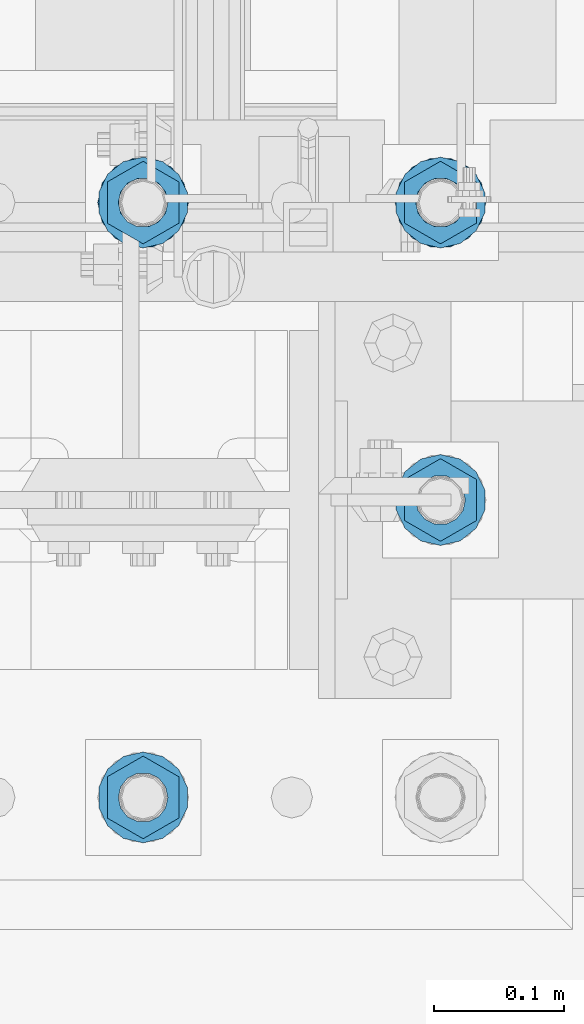
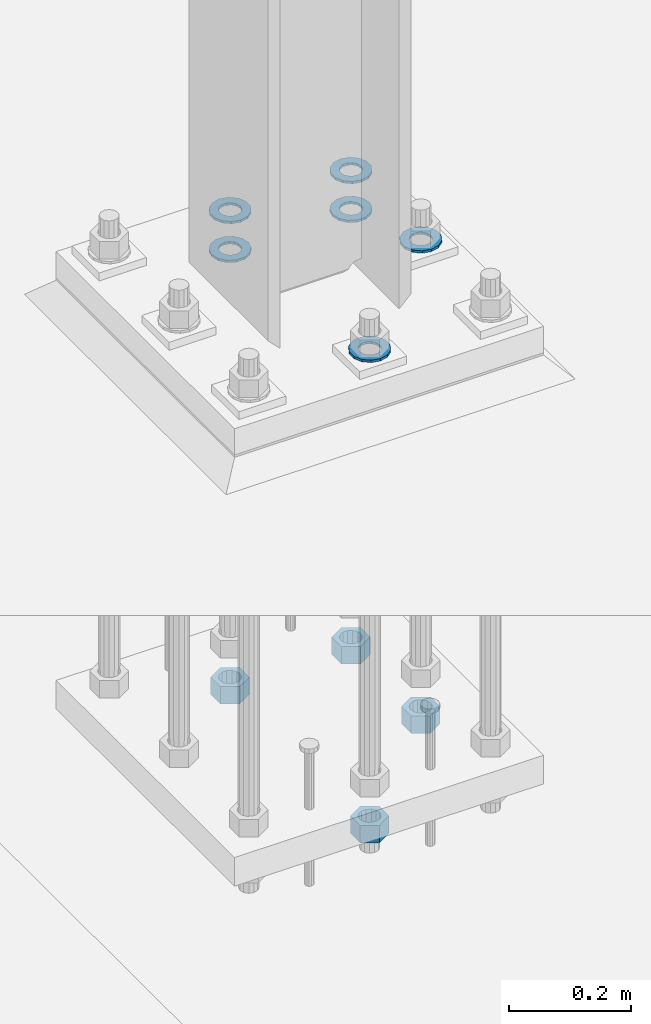
# One storey, part 889 of 1876: 10 columns, 1 element without a shape of its own.
"""IFC2X3 building model written with IfcOpenShell, lengths in millimetres."""

from ifc_helpers import new_model, si_unit, frame, origin_with_axes, place, context, subcontext, project, spatial, faceted_brep, material, type_object, element, aggregate, save


model = new_model("IFC2X3")

# Units and contexts
model_context = context("Model", 3, precision=1e-05, world=origin_with_axes())
body_context = subcontext(model_context, "Body", "Model", "MODEL_VIEW")
ifc_project = project(units=[si_unit("LENGTHUNIT", "METRE", prefix="MILLI"), si_unit("AREAUNIT", "SQUARE_METRE"), si_unit("VOLUMEUNIT", "CUBIC_METRE"), si_unit("MASSUNIT", "GRAM", prefix="KILO"), si_unit("TIMEUNIT", "SECOND"), si_unit("PLANEANGLEUNIT", "RADIAN"), si_unit("SOLIDANGLEUNIT", "STERADIAN"), si_unit("THERMODYNAMICTEMPERATUREUNIT", "DEGREE_CELSIUS"), si_unit("LUMINOUSINTENSITYUNIT", "LUMEN")], contexts=[model_context])

# Site, building, storey
site_placement = place(None, origin_with_axes())
site = spatial("IfcSite", under=ifc_project, at=site_placement, CompositionType="ELEMENT")
building_placement = place(site_placement, origin_with_axes())
building = spatial("IfcBuilding", under=site, at=building_placement, Name="Undefined", CompositionType="ELEMENT")
storey_placement = place(building_placement, origin_with_axes())
storey = spatial("IfcBuildingStorey", under=building, at=storey_placement, Name="Undefined", CompositionType="ELEMENT", Elevation=0.0)

# Assembly, columns
assembly_placement = place(storey_placement, origin_with_axes())
assembly = element("IfcElementAssembly", 1, at=assembly_placement, inside=storey, Name="TEMPLATE", AssemblyPlace="NOTDEFINED", PredefinedType="RIGID_FRAME")
ifc_material_1 = material(Name="STEEL/F436")
column_type_1 = type_object("IfcColumnType", Name="1-3/8_WASHER", PredefinedType="NOTDEFINED")
column_1_placement = place(assembly_placement, frame((1955.8, -6883.4, 38.1), z_axis=(0.0, -1.0, 0.0), x_axis=(0.0, 0.0, -1.0)))
column_1 = element("IfcColumn", 2, at=column_1_placement, type_object=column_type_1, material=ifc_material_1, Name="WASHER", ObjectType="1-3/8_WASHER", context=body_context, shape_type="Brep", body=[
    faceted_brep([(0.0, -34.9199981689453, 0.0), (0.0, -31.4618312174289, -15.1512193755207), (4.7625, -31.4618312174289, -15.1512193755207), (4.7625, -34.9199981689453, 0.0), (0.0, -21.7722627392632, -27.3015539362077), (4.7625, -21.7722627392632, -27.3015539362077), (0.0, -7.77043060630604, -34.0444809082428), (4.7625, -7.77043060630604, -34.0444809082428), (0.0, 7.77043060630695, -34.0444809082428), (4.7625, 7.77043060630695, -34.0444809082428), (0.0, 21.7722627392632, -27.3015539362077), (4.7625, 21.7722627392632, -27.3015539362077), (0.0, 31.4618312174298, -15.1512193755207), (4.7625, 31.4618312174298, -15.1512193755207), (0.0, 34.9199981689453, 0.0), (4.7625, 34.9199981689453, 0.0), (0.0, 31.4618312174289, 15.1512193755207), (4.7625, 31.4618312174289, 15.1512193755207), (0.0, 21.7722627392632, 27.3015539362077), (4.7625, 21.7722627392632, 27.3015539362077), (0.0, 7.77043060630604, 34.0444809082428), (4.7625, 7.77043060630604, 34.0444809082428), (0.0, -7.77043060630695, 34.0444809082428), (4.7625, -7.77043060630695, 34.0444809082428), (0.0, -21.7722627392632, 27.3015539362077), (4.7625, -21.7722627392632, 27.3015539362077), (0.0, -31.4618312174298, 15.1512193755207), (4.7625, -31.4618312174298, 15.1512193755207), (0.0, 0.0, 19.0499999999993), (0.0, 8.2654848991624, 17.1634562461559), (4.7625, 8.2654848991624, 17.1634562461559), (4.7625, 0.0, 19.0499992370605), (0.0, 14.8938891445259, 11.8774802497237), (4.7625, 14.8938891445259, 11.8774802497237), (0.0, 18.5723759832526, 4.2390236220981), (4.7625, 18.5723759832526, 4.2390236220981), (0.0, 18.5723759832526, -4.2390236220981), (4.7625, 18.5723759832526, -4.2390236220981), (0.0, 14.8938891445259, -11.8774802497237), (4.7625, 14.8938891445259, -11.8774802497237), (0.0, 8.2654848991624, -17.1634562461568), (4.7625, 8.2654848991624, -17.1634562461568), (0.0, 0.0, -19.05), (4.7625, 0.0, -19.0499992370605), (0.0, -8.2654848991624, -17.1634562461559), (4.7625, -8.2654848991624, -17.1634562461559), (0.0, -14.8938891445259, -11.8774802497237), (4.7625, -14.8938891445259, -11.8774802497237), (0.0, -18.5723759832526, -4.2390236220981), (4.7625, -18.5723759832526, -4.2390236220981), (0.0, -18.5723759832526, 4.2390236220981), (4.7625, -18.5723759832526, 4.2390236220981), (0.0, -14.8938891445259, 11.8774802497237), (4.7625, -14.8938891445259, 11.8774802497237), (0.0, -8.2654848991624, 17.1634562461568), (4.7625, -8.2654848991624, 17.1634562461568)], [[[0, 1, 2, 3]], [[1, 4, 5, 2]], [[4, 6, 7, 5]], [[6, 8, 9, 7]], [[8, 10, 11, 9]], [[10, 12, 13, 11]], [[12, 14, 15, 13]], [[14, 16, 17, 15]], [[16, 18, 19, 17]], [[18, 20, 21, 19]], [[20, 22, 23, 21]], [[22, 24, 25, 23]], [[24, 26, 27, 25]], [[26, 0, 3, 27]], [[28, 29, 30, 31]], [[29, 32, 33, 30]], [[32, 34, 35, 33]], [[34, 36, 37, 35]], [[36, 38, 39, 37]], [[38, 40, 41, 39]], [[40, 42, 43, 41]], [[42, 44, 45, 43]], [[44, 46, 47, 45]], [[46, 48, 49, 47]], [[48, 50, 51, 49]], [[50, 52, 53, 51]], [[52, 54, 55, 53]], [[54, 28, 31, 55]], [[5, 7, 9, 11, 13, 15, 17, 19, 21, 23, 25, 27, 3, 2], [33, 35, 37, 39, 41, 43, 45, 47, 49, 51, 53, 55, 31, 30]], [[26, 24, 22, 20, 18, 16, 14, 12, 10, 8, 6, 4, 1, 0], [54, 52, 50, 48, 46, 44, 42, 40, 38, 36, 34, 32, 29, 28]]]),
])
column_2_placement = place(assembly_placement, frame((1727.2, -6883.4, 38.1), z_axis=(0.0, -1.0, 0.0), x_axis=(0.0, 0.0, -1.0)))
column_2 = element("IfcColumn", 3, at=column_2_placement, type_object=column_type_1, material=ifc_material_1, Name="WASHER", ObjectType="1-3/8_WASHER", context=body_context, shape_type="Brep", body=[
    faceted_brep([(0.0, -34.9199981689453, 0.0), (0.0, -31.4618312174289, -15.1512193755207), (4.7625, -31.4618312174289, -15.1512193755207), (4.7625, -34.9199981689453, 0.0), (0.0, -21.7722627392632, -27.3015539362077), (4.7625, -21.7722627392632, -27.3015539362077), (0.0, -7.77043060630604, -34.0444809082428), (4.7625, -7.77043060630604, -34.0444809082428), (0.0, 7.77043060630695, -34.0444809082428), (4.7625, 7.77043060630695, -34.0444809082428), (0.0, 21.7722627392632, -27.3015539362077), (4.7625, 21.7722627392632, -27.3015539362077), (0.0, 31.4618312174298, -15.1512193755207), (4.7625, 31.4618312174298, -15.1512193755207), (0.0, 34.9199981689453, 0.0), (4.7625, 34.9199981689453, 0.0), (0.0, 31.4618312174289, 15.1512193755207), (4.7625, 31.4618312174289, 15.1512193755207), (0.0, 21.7722627392632, 27.3015539362077), (4.7625, 21.7722627392632, 27.3015539362077), (0.0, 7.77043060630604, 34.0444809082428), (4.7625, 7.77043060630604, 34.0444809082428), (0.0, -7.77043060630695, 34.0444809082428), (4.7625, -7.77043060630695, 34.0444809082428), (0.0, -21.7722627392632, 27.3015539362077), (4.7625, -21.7722627392632, 27.3015539362077), (0.0, -31.4618312174298, 15.1512193755207), (4.7625, -31.4618312174298, 15.1512193755207), (0.0, 0.0, 19.0499999999993), (0.0, 8.2654848991624, 17.1634562461559), (4.7625, 8.2654848991624, 17.1634562461559), (4.7625, 0.0, 19.0499992370605), (0.0, 14.8938891445259, 11.8774802497237), (4.7625, 14.8938891445259, 11.8774802497237), (0.0, 18.5723759832526, 4.2390236220981), (4.7625, 18.5723759832526, 4.2390236220981), (0.0, 18.5723759832526, -4.2390236220981), (4.7625, 18.5723759832526, -4.2390236220981), (0.0, 14.8938891445259, -11.8774802497237), (4.7625, 14.8938891445259, -11.8774802497237), (0.0, 8.2654848991624, -17.1634562461568), (4.7625, 8.2654848991624, -17.1634562461568), (0.0, 0.0, -19.05), (4.7625, 0.0, -19.0499992370605), (0.0, -8.2654848991624, -17.1634562461559), (4.7625, -8.2654848991624, -17.1634562461559), (0.0, -14.8938891445259, -11.8774802497237), (4.7625, -14.8938891445259, -11.8774802497237), (0.0, -18.5723759832526, -4.2390236220981), (4.7625, -18.5723759832526, -4.2390236220981), (0.0, -18.5723759832526, 4.2390236220981), (4.7625, -18.5723759832526, 4.2390236220981), (0.0, -14.8938891445259, 11.8774802497237), (4.7625, -14.8938891445259, 11.8774802497237), (0.0, -8.2654848991624, 17.1634562461568), (4.7625, -8.2654848991624, 17.1634562461568)], [[[0, 1, 2, 3]], [[1, 4, 5, 2]], [[4, 6, 7, 5]], [[6, 8, 9, 7]], [[8, 10, 11, 9]], [[10, 12, 13, 11]], [[12, 14, 15, 13]], [[14, 16, 17, 15]], [[16, 18, 19, 17]], [[18, 20, 21, 19]], [[20, 22, 23, 21]], [[22, 24, 25, 23]], [[24, 26, 27, 25]], [[26, 0, 3, 27]], [[28, 29, 30, 31]], [[29, 32, 33, 30]], [[32, 34, 35, 33]], [[34, 36, 37, 35]], [[36, 38, 39, 37]], [[38, 40, 41, 39]], [[40, 42, 43, 41]], [[42, 44, 45, 43]], [[44, 46, 47, 45]], [[46, 48, 49, 47]], [[48, 50, 51, 49]], [[50, 52, 53, 51]], [[52, 54, 55, 53]], [[54, 28, 31, 55]], [[5, 7, 9, 11, 13, 15, 17, 19, 21, 23, 25, 27, 3, 2], [33, 35, 37, 39, 41, 43, 45, 47, 49, 51, 53, 55, 31, 30]], [[26, 24, 22, 20, 18, 16, 14, 12, 10, 8, 6, 4, 1, 0], [54, 52, 50, 48, 46, 44, 42, 40, 38, 36, 34, 32, 29, 28]]]),
])
column_3_placement = place(assembly_placement, frame((1955.8, -7112.0, 115.8875), z_axis=(1.0, 0.0, 0.0), x_axis=(0.0, 0.0, -1.0)))
column_3 = element("IfcColumn", 4, at=column_3_placement, type_object=column_type_1, material=ifc_material_1, Name="WASHER", ObjectType="1-3/8_WASHER", context=body_context, shape_type="Brep", body=[
    faceted_brep([(0.0, -34.9199981689453, 0.0), (0.0, -31.4618312174289, -15.1512193755207), (4.7625, -31.4618312174289, -15.1512193755207), (4.7625, -34.9199981689453, 0.0), (0.0, -21.7722627392632, -27.3015539362077), (4.7625, -21.7722627392632, -27.3015539362077), (0.0, -7.77043060630604, -34.0444809082428), (4.7625, -7.77043060630604, -34.0444809082428), (0.0, 7.77043060630695, -34.0444809082428), (4.7625, 7.77043060630695, -34.0444809082428), (0.0, 21.7722627392632, -27.3015539362077), (4.7625, 21.7722627392632, -27.3015539362077), (0.0, 31.4618312174298, -15.1512193755207), (4.7625, 31.4618312174298, -15.1512193755207), (0.0, 34.9199981689453, 0.0), (4.7625, 34.9199981689453, 0.0), (0.0, 31.4618312174289, 15.1512193755207), (4.7625, 31.4618312174289, 15.1512193755207), (0.0, 21.7722627392632, 27.3015539362077), (4.7625, 21.7722627392632, 27.3015539362077), (0.0, 7.77043060630604, 34.0444809082428), (4.7625, 7.77043060630604, 34.0444809082428), (0.0, -7.77043060630695, 34.0444809082428), (4.7625, -7.77043060630695, 34.0444809082428), (0.0, -21.7722627392632, 27.3015539362077), (4.7625, -21.7722627392632, 27.3015539362077), (0.0, -31.4618312174298, 15.1512193755207), (4.7625, -31.4618312174298, 15.1512193755207), (0.0, 0.0, 19.0499999999993), (0.0, 8.2654848991624, 17.1634562461559), (4.7625, 8.2654848991624, 17.1634562461559), (4.7625, 0.0, 19.0499992370605), (0.0, 14.8938891445259, 11.8774802497237), (4.7625, 14.8938891445259, 11.8774802497237), (0.0, 18.5723759832526, 4.2390236220981), (4.7625, 18.5723759832526, 4.2390236220981), (0.0, 18.5723759832526, -4.2390236220981), (4.7625, 18.5723759832526, -4.2390236220981), (0.0, 14.8938891445259, -11.8774802497237), (4.7625, 14.8938891445259, -11.8774802497237), (0.0, 8.2654848991624, -17.1634562461568), (4.7625, 8.2654848991624, -17.1634562461568), (0.0, 0.0, -19.05), (4.7625, 0.0, -19.0499992370605), (0.0, -8.2654848991624, -17.1634562461559), (4.7625, -8.2654848991624, -17.1634562461559), (0.0, -14.8938891445259, -11.8774802497237), (4.7625, -14.8938891445259, -11.8774802497237), (0.0, -18.5723759832526, -4.2390236220981), (4.7625, -18.5723759832526, -4.2390236220981), (0.0, -18.5723759832526, 4.2390236220981), (4.7625, -18.5723759832526, 4.2390236220981), (0.0, -14.8938891445259, 11.8774802497237), (4.7625, -14.8938891445259, 11.8774802497237), (0.0, -8.2654848991624, 17.1634562461568), (4.7625, -8.2654848991624, 17.1634562461568)], [[[0, 1, 2, 3]], [[1, 4, 5, 2]], [[4, 6, 7, 5]], [[6, 8, 9, 7]], [[8, 10, 11, 9]], [[10, 12, 13, 11]], [[12, 14, 15, 13]], [[14, 16, 17, 15]], [[16, 18, 19, 17]], [[18, 20, 21, 19]], [[20, 22, 23, 21]], [[22, 24, 25, 23]], [[24, 26, 27, 25]], [[26, 0, 3, 27]], [[28, 29, 30, 31]], [[29, 32, 33, 30]], [[32, 34, 35, 33]], [[34, 36, 37, 35]], [[36, 38, 39, 37]], [[38, 40, 41, 39]], [[40, 42, 43, 41]], [[42, 44, 45, 43]], [[44, 46, 47, 45]], [[46, 48, 49, 47]], [[48, 50, 51, 49]], [[50, 52, 53, 51]], [[52, 54, 55, 53]], [[54, 28, 31, 55]], [[5, 7, 9, 11, 13, 15, 17, 19, 21, 23, 25, 27, 3, 2], [33, 35, 37, 39, 41, 43, 45, 47, 49, 51, 53, 55, 31, 30]], [[26, 24, 22, 20, 18, 16, 14, 12, 10, 8, 6, 4, 1, 0], [54, 52, 50, 48, 46, 44, 42, 40, 38, 36, 34, 32, 29, 28]]]),
])
column_4_placement = place(assembly_placement, frame((1955.8, -6883.4, 115.8875), z_axis=(-1.0, 0.0, 0.0), x_axis=(0.0, 0.0, -1.0)))
column_4 = element("IfcColumn", 5, at=column_4_placement, type_object=column_type_1, material=ifc_material_1, Name="WASHER", ObjectType="1-3/8_WASHER", context=body_context, shape_type="Brep", body=[
    faceted_brep([(0.0, -34.9199981689453, 0.0), (0.0, -31.4618312174289, -15.1512193755207), (4.7625, -31.4618312174289, -15.1512193755207), (4.7625, -34.9199981689453, 0.0), (0.0, -21.7722627392632, -27.3015539362077), (4.7625, -21.7722627392632, -27.3015539362077), (0.0, -7.77043060630604, -34.0444809082428), (4.7625, -7.77043060630604, -34.0444809082428), (0.0, 7.77043060630695, -34.0444809082428), (4.7625, 7.77043060630695, -34.0444809082428), (0.0, 21.7722627392632, -27.3015539362077), (4.7625, 21.7722627392632, -27.3015539362077), (0.0, 31.4618312174298, -15.1512193755207), (4.7625, 31.4618312174298, -15.1512193755207), (0.0, 34.9199981689453, 0.0), (4.7625, 34.9199981689453, 0.0), (0.0, 31.4618312174289, 15.1512193755207), (4.7625, 31.4618312174289, 15.1512193755207), (0.0, 21.7722627392632, 27.3015539362077), (4.7625, 21.7722627392632, 27.3015539362077), (0.0, 7.77043060630604, 34.0444809082428), (4.7625, 7.77043060630604, 34.0444809082428), (0.0, -7.77043060630695, 34.0444809082428), (4.7625, -7.77043060630695, 34.0444809082428), (0.0, -21.7722627392632, 27.3015539362077), (4.7625, -21.7722627392632, 27.3015539362077), (0.0, -31.4618312174298, 15.1512193755207), (4.7625, -31.4618312174298, 15.1512193755207), (0.0, 0.0, 19.0499999999993), (0.0, 8.2654848991624, 17.1634562461559), (4.7625, 8.2654848991624, 17.1634562461559), (4.7625, 0.0, 19.0499992370605), (0.0, 14.8938891445259, 11.8774802497237), (4.7625, 14.8938891445259, 11.8774802497237), (0.0, 18.5723759832526, 4.2390236220981), (4.7625, 18.5723759832526, 4.2390236220981), (0.0, 18.5723759832526, -4.2390236220981), (4.7625, 18.5723759832526, -4.2390236220981), (0.0, 14.8938891445259, -11.8774802497237), (4.7625, 14.8938891445259, -11.8774802497237), (0.0, 8.2654848991624, -17.1634562461568), (4.7625, 8.2654848991624, -17.1634562461568), (0.0, 0.0, -19.05), (4.7625, 0.0, -19.0499992370605), (0.0, -8.2654848991624, -17.1634562461559), (4.7625, -8.2654848991624, -17.1634562461559), (0.0, -14.8938891445259, -11.8774802497237), (4.7625, -14.8938891445259, -11.8774802497237), (0.0, -18.5723759832526, -4.2390236220981), (4.7625, -18.5723759832526, -4.2390236220981), (0.0, -18.5723759832526, 4.2390236220981), (4.7625, -18.5723759832526, 4.2390236220981), (0.0, -14.8938891445259, 11.8774802497237), (4.7625, -14.8938891445259, 11.8774802497237), (0.0, -8.2654848991624, 17.1634562461568), (4.7625, -8.2654848991624, 17.1634562461568)], [[[0, 1, 2, 3]], [[1, 4, 5, 2]], [[4, 6, 7, 5]], [[6, 8, 9, 7]], [[8, 10, 11, 9]], [[10, 12, 13, 11]], [[12, 14, 15, 13]], [[14, 16, 17, 15]], [[16, 18, 19, 17]], [[18, 20, 21, 19]], [[20, 22, 23, 21]], [[22, 24, 25, 23]], [[24, 26, 27, 25]], [[26, 0, 3, 27]], [[28, 29, 30, 31]], [[29, 32, 33, 30]], [[32, 34, 35, 33]], [[34, 36, 37, 35]], [[36, 38, 39, 37]], [[38, 40, 41, 39]], [[40, 42, 43, 41]], [[42, 44, 45, 43]], [[44, 46, 47, 45]], [[46, 48, 49, 47]], [[48, 50, 51, 49]], [[50, 52, 53, 51]], [[52, 54, 55, 53]], [[54, 28, 31, 55]], [[5, 7, 9, 11, 13, 15, 17, 19, 21, 23, 25, 27, 3, 2], [33, 35, 37, 39, 41, 43, 45, 47, 49, 51, 53, 55, 31, 30]], [[26, 24, 22, 20, 18, 16, 14, 12, 10, 8, 6, 4, 1, 0], [54, 52, 50, 48, 46, 44, 42, 40, 38, 36, 34, 32, 29, 28]]]),
])
column_5_placement = place(assembly_placement, frame((1727.2, -7340.6, 115.8875), z_axis=(1.0, 0.0, 0.0), x_axis=(0.0, 0.0, -1.0)))
column_5 = element("IfcColumn", 6, at=column_5_placement, type_object=column_type_1, material=ifc_material_1, Name="WASHER", ObjectType="1-3/8_WASHER", context=body_context, shape_type="Brep", body=[
    faceted_brep([(0.0, -34.9199981689453, 0.0), (0.0, -31.4618312174289, -15.1512193755207), (4.7625, -31.4618312174289, -15.1512193755207), (4.7625, -34.9199981689453, 0.0), (0.0, -21.7722627392632, -27.3015539362077), (4.7625, -21.7722627392632, -27.3015539362077), (0.0, -7.77043060630604, -34.0444809082428), (4.7625, -7.77043060630604, -34.0444809082428), (0.0, 7.77043060630695, -34.0444809082428), (4.7625, 7.77043060630695, -34.0444809082428), (0.0, 21.7722627392632, -27.3015539362077), (4.7625, 21.7722627392632, -27.3015539362077), (0.0, 31.4618312174298, -15.1512193755207), (4.7625, 31.4618312174298, -15.1512193755207), (0.0, 34.9199981689453, 0.0), (4.7625, 34.9199981689453, 0.0), (0.0, 31.4618312174289, 15.1512193755207), (4.7625, 31.4618312174289, 15.1512193755207), (0.0, 21.7722627392632, 27.3015539362077), (4.7625, 21.7722627392632, 27.3015539362077), (0.0, 7.77043060630604, 34.0444809082428), (4.7625, 7.77043060630604, 34.0444809082428), (0.0, -7.77043060630695, 34.0444809082428), (4.7625, -7.77043060630695, 34.0444809082428), (0.0, -21.7722627392632, 27.3015539362077), (4.7625, -21.7722627392632, 27.3015539362077), (0.0, -31.4618312174298, 15.1512193755207), (4.7625, -31.4618312174298, 15.1512193755207), (0.0, 0.0, 19.0499999999993), (0.0, 8.2654848991624, 17.1634562461559), (4.7625, 8.2654848991624, 17.1634562461559), (4.7625, 0.0, 19.0499992370605), (0.0, 14.8938891445259, 11.8774802497237), (4.7625, 14.8938891445259, 11.8774802497237), (0.0, 18.5723759832526, 4.2390236220981), (4.7625, 18.5723759832526, 4.2390236220981), (0.0, 18.5723759832526, -4.2390236220981), (4.7625, 18.5723759832526, -4.2390236220981), (0.0, 14.8938891445259, -11.8774802497237), (4.7625, 14.8938891445259, -11.8774802497237), (0.0, 8.2654848991624, -17.1634562461568), (4.7625, 8.2654848991624, -17.1634562461568), (0.0, 0.0, -19.05), (4.7625, 0.0, -19.0499992370605), (0.0, -8.2654848991624, -17.1634562461559), (4.7625, -8.2654848991624, -17.1634562461559), (0.0, -14.8938891445259, -11.8774802497237), (4.7625, -14.8938891445259, -11.8774802497237), (0.0, -18.5723759832526, -4.2390236220981), (4.7625, -18.5723759832526, -4.2390236220981), (0.0, -18.5723759832526, 4.2390236220981), (4.7625, -18.5723759832526, 4.2390236220981), (0.0, -14.8938891445259, 11.8774802497237), (4.7625, -14.8938891445259, 11.8774802497237), (0.0, -8.2654848991624, 17.1634562461568), (4.7625, -8.2654848991624, 17.1634562461568)], [[[0, 1, 2, 3]], [[1, 4, 5, 2]], [[4, 6, 7, 5]], [[6, 8, 9, 7]], [[8, 10, 11, 9]], [[10, 12, 13, 11]], [[12, 14, 15, 13]], [[14, 16, 17, 15]], [[16, 18, 19, 17]], [[18, 20, 21, 19]], [[20, 22, 23, 21]], [[22, 24, 25, 23]], [[24, 26, 27, 25]], [[26, 0, 3, 27]], [[28, 29, 30, 31]], [[29, 32, 33, 30]], [[32, 34, 35, 33]], [[34, 36, 37, 35]], [[36, 38, 39, 37]], [[38, 40, 41, 39]], [[40, 42, 43, 41]], [[42, 44, 45, 43]], [[44, 46, 47, 45]], [[46, 48, 49, 47]], [[48, 50, 51, 49]], [[50, 52, 53, 51]], [[52, 54, 55, 53]], [[54, 28, 31, 55]], [[5, 7, 9, 11, 13, 15, 17, 19, 21, 23, 25, 27, 3, 2], [33, 35, 37, 39, 41, 43, 45, 47, 49, 51, 53, 55, 31, 30]], [[26, 24, 22, 20, 18, 16, 14, 12, 10, 8, 6, 4, 1, 0], [54, 52, 50, 48, 46, 44, 42, 40, 38, 36, 34, 32, 29, 28]]]),
])
column_6_placement = place(assembly_placement, frame((1727.2, -6883.4, 115.8875), z_axis=(-1.0, 0.0, 0.0), x_axis=(0.0, 0.0, -1.0)))
column_6 = element("IfcColumn", 7, at=column_6_placement, type_object=column_type_1, material=ifc_material_1, Name="WASHER", ObjectType="1-3/8_WASHER", context=body_context, shape_type="Brep", body=[
    faceted_brep([(0.0, -34.9199981689453, 0.0), (0.0, -31.4618312174289, -15.1512193755207), (4.7625, -31.4618312174289, -15.1512193755207), (4.7625, -34.9199981689453, 0.0), (0.0, -21.7722627392632, -27.3015539362077), (4.7625, -21.7722627392632, -27.3015539362077), (0.0, -7.77043060630604, -34.0444809082428), (4.7625, -7.77043060630604, -34.0444809082428), (0.0, 7.77043060630695, -34.0444809082428), (4.7625, 7.77043060630695, -34.0444809082428), (0.0, 21.7722627392632, -27.3015539362077), (4.7625, 21.7722627392632, -27.3015539362077), (0.0, 31.4618312174298, -15.1512193755207), (4.7625, 31.4618312174298, -15.1512193755207), (0.0, 34.9199981689453, 0.0), (4.7625, 34.9199981689453, 0.0), (0.0, 31.4618312174289, 15.1512193755207), (4.7625, 31.4618312174289, 15.1512193755207), (0.0, 21.7722627392632, 27.3015539362077), (4.7625, 21.7722627392632, 27.3015539362077), (0.0, 7.77043060630604, 34.0444809082428), (4.7625, 7.77043060630604, 34.0444809082428), (0.0, -7.77043060630695, 34.0444809082428), (4.7625, -7.77043060630695, 34.0444809082428), (0.0, -21.7722627392632, 27.3015539362077), (4.7625, -21.7722627392632, 27.3015539362077), (0.0, -31.4618312174298, 15.1512193755207), (4.7625, -31.4618312174298, 15.1512193755207), (0.0, 0.0, 19.0499999999993), (0.0, 8.2654848991624, 17.1634562461559), (4.7625, 8.2654848991624, 17.1634562461559), (4.7625, 0.0, 19.0499992370605), (0.0, 14.8938891445259, 11.8774802497237), (4.7625, 14.8938891445259, 11.8774802497237), (0.0, 18.5723759832526, 4.2390236220981), (4.7625, 18.5723759832526, 4.2390236220981), (0.0, 18.5723759832526, -4.2390236220981), (4.7625, 18.5723759832526, -4.2390236220981), (0.0, 14.8938891445259, -11.8774802497237), (4.7625, 14.8938891445259, -11.8774802497237), (0.0, 8.2654848991624, -17.1634562461568), (4.7625, 8.2654848991624, -17.1634562461568), (0.0, 0.0, -19.05), (4.7625, 0.0, -19.0499992370605), (0.0, -8.2654848991624, -17.1634562461559), (4.7625, -8.2654848991624, -17.1634562461559), (0.0, -14.8938891445259, -11.8774802497237), (4.7625, -14.8938891445259, -11.8774802497237), (0.0, -18.5723759832526, -4.2390236220981), (4.7625, -18.5723759832526, -4.2390236220981), (0.0, -18.5723759832526, 4.2390236220981), (4.7625, -18.5723759832526, 4.2390236220981), (0.0, -14.8938891445259, 11.8774802497237), (4.7625, -14.8938891445259, 11.8774802497237), (0.0, -8.2654848991624, 17.1634562461568), (4.7625, -8.2654848991624, 17.1634562461568)], [[[0, 1, 2, 3]], [[1, 4, 5, 2]], [[4, 6, 7, 5]], [[6, 8, 9, 7]], [[8, 10, 11, 9]], [[10, 12, 13, 11]], [[12, 14, 15, 13]], [[14, 16, 17, 15]], [[16, 18, 19, 17]], [[18, 20, 21, 19]], [[20, 22, 23, 21]], [[22, 24, 25, 23]], [[24, 26, 27, 25]], [[26, 0, 3, 27]], [[28, 29, 30, 31]], [[29, 32, 33, 30]], [[32, 34, 35, 33]], [[34, 36, 37, 35]], [[36, 38, 39, 37]], [[38, 40, 41, 39]], [[40, 42, 43, 41]], [[42, 44, 45, 43]], [[44, 46, 47, 45]], [[46, 48, 49, 47]], [[48, 50, 51, 49]], [[50, 52, 53, 51]], [[52, 54, 55, 53]], [[54, 28, 31, 55]], [[5, 7, 9, 11, 13, 15, 17, 19, 21, 23, 25, 27, 3, 2], [33, 35, 37, 39, 41, 43, 45, 47, 49, 51, 53, 55, 31, 30]], [[26, 24, 22, 20, 18, 16, 14, 12, 10, 8, 6, 4, 1, 0], [54, 52, 50, 48, 46, 44, 42, 40, 38, 36, 34, 32, 29, 28]]]),
])
ifc_material_2 = material(Name="STEEL/A563")
column_type_2 = type_object("IfcColumnType", Name="1-3/8_HEAVY_HEX_NUT", PredefinedType="NOTDEFINED")
column_7_placement = place(assembly_placement, frame((1955.8, -7112.0, -819.15), z_axis=(1.0, 0.0, 0.0), x_axis=(0.0, 0.0, -1.0)))
column_7 = element("IfcColumn", 8, at=column_7_placement, type_object=column_type_2, material=ifc_material_2, Name="NUT", ObjectType="1-3/8_HEAVY_HEX_NUT", context=body_context, shape_type="Brep", body=[
    faceted_brep([(0.0, -31.75, 0.0), (0.0, -15.8800001144409, -27.5), (34.925, -15.8800001144409, -27.5), (34.925, -31.75, 0.0), (0.0, 15.8800001144409, -27.5), (34.925, 15.8800001144409, -27.5), (0.0, 31.75, 0.0), (34.925, 31.75, 0.0), (0.0, 15.8800001144409, 27.5), (34.925, 15.8800001144409, 27.5), (0.0, -15.8800001144409, 27.5), (34.925, -15.8800001144409, 27.5), (0.0, 0.0, 19.0499999999993), (0.0, 8.2654848991624, 17.1634562461559), (34.925, 8.26548489916252, 17.163456246155), (34.925, 0.0, 19.0499992370605), (0.0, 14.8938891445259, 11.8774802497237), (34.925, 14.8938891445259, 11.8774802497246), (0.0, 18.5723759832526, 4.2390236220981), (34.925, 18.5723759832528, 4.23902362209628), (0.0, 18.5723759832526, -4.2390236220981), (34.925, 18.5723759832528, -4.23902362209628), (0.0, 14.8938891445259, -11.8774802497237), (34.925, 14.8938891445259, -11.8774802497246), (0.0, 8.2654848991624, -17.1634562461568), (34.925, 8.26548489916252, -17.163456246155), (0.0, 0.0, -19.05), (34.925, 0.0, -19.0499992370605), (0.0, -8.2654848991624, -17.1634562461559), (34.925, -8.26548489916252, -17.163456246155), (0.0, -14.8938891445259, -11.8774802497237), (34.925, -14.8938891445259, -11.8774802497246), (0.0, -18.5723759832526, -4.2390236220981), (34.925, -18.5723759832528, -4.23902362209628), (0.0, -18.5723759832526, 4.2390236220981), (34.925, -18.5723759832528, 4.23902362209628), (0.0, -14.8938891445259, 11.8774802497237), (34.925, -14.8938891445259, 11.8774802497246), (0.0, -8.2654848991624, 17.1634562461568), (34.925, -8.26548489916252, 17.163456246155)], [[[0, 1, 2, 3]], [[1, 4, 5, 2]], [[4, 6, 7, 5]], [[6, 8, 9, 7]], [[8, 10, 11, 9]], [[10, 0, 3, 11]], [[12, 13, 14, 15]], [[13, 16, 17, 14]], [[16, 18, 19, 17]], [[18, 20, 21, 19]], [[20, 22, 23, 21]], [[22, 24, 25, 23]], [[24, 26, 27, 25]], [[26, 28, 29, 27]], [[28, 30, 31, 29]], [[30, 32, 33, 31]], [[32, 34, 35, 33]], [[34, 36, 37, 35]], [[36, 38, 39, 37]], [[38, 12, 15, 39]], [[5, 7, 9, 11, 3, 2], [17, 19, 21, 23, 25, 27, 29, 31, 33, 35, 37, 39, 15, 14]], [[10, 8, 6, 4, 1, 0], [38, 36, 34, 32, 30, 28, 26, 24, 22, 20, 18, 16, 13, 12]]]),
])
column_8_placement = place(assembly_placement, frame((1955.8, -6883.4, -819.15), z_axis=(-1.0, 0.0, 0.0), x_axis=(0.0, 0.0, -1.0)))
column_8 = element("IfcColumn", 9, at=column_8_placement, type_object=column_type_2, material=ifc_material_2, Name="NUT", ObjectType="1-3/8_HEAVY_HEX_NUT", context=body_context, shape_type="Brep", body=[
    faceted_brep([(0.0, -31.75, 0.0), (0.0, -15.8800001144409, -27.5), (34.925, -15.8800001144409, -27.5), (34.925, -31.75, 0.0), (0.0, 15.8800001144409, -27.5), (34.925, 15.8800001144409, -27.5), (0.0, 31.75, 0.0), (34.925, 31.75, 0.0), (0.0, 15.8800001144409, 27.5), (34.925, 15.8800001144409, 27.5), (0.0, -15.8800001144409, 27.5), (34.925, -15.8800001144409, 27.5), (0.0, 0.0, 19.0499999999993), (0.0, 8.2654848991624, 17.1634562461559), (34.925, 8.26548489916252, 17.163456246155), (34.925, 0.0, 19.0499992370605), (0.0, 14.8938891445259, 11.8774802497237), (34.925, 14.8938891445259, 11.8774802497246), (0.0, 18.5723759832526, 4.2390236220981), (34.925, 18.5723759832528, 4.23902362209628), (0.0, 18.5723759832526, -4.2390236220981), (34.925, 18.5723759832528, -4.23902362209628), (0.0, 14.8938891445259, -11.8774802497237), (34.925, 14.8938891445259, -11.8774802497246), (0.0, 8.2654848991624, -17.1634562461568), (34.925, 8.26548489916252, -17.163456246155), (0.0, 0.0, -19.05), (34.925, 0.0, -19.0499992370605), (0.0, -8.2654848991624, -17.1634562461559), (34.925, -8.26548489916252, -17.163456246155), (0.0, -14.8938891445259, -11.8774802497237), (34.925, -14.8938891445259, -11.8774802497246), (0.0, -18.5723759832526, -4.2390236220981), (34.925, -18.5723759832528, -4.23902362209628), (0.0, -18.5723759832526, 4.2390236220981), (34.925, -18.5723759832528, 4.23902362209628), (0.0, -14.8938891445259, 11.8774802497237), (34.925, -14.8938891445259, 11.8774802497246), (0.0, -8.2654848991624, 17.1634562461568), (34.925, -8.26548489916252, 17.163456246155)], [[[0, 1, 2, 3]], [[1, 4, 5, 2]], [[4, 6, 7, 5]], [[6, 8, 9, 7]], [[8, 10, 11, 9]], [[10, 0, 3, 11]], [[12, 13, 14, 15]], [[13, 16, 17, 14]], [[16, 18, 19, 17]], [[18, 20, 21, 19]], [[20, 22, 23, 21]], [[22, 24, 25, 23]], [[24, 26, 27, 25]], [[26, 28, 29, 27]], [[28, 30, 31, 29]], [[30, 32, 33, 31]], [[32, 34, 35, 33]], [[34, 36, 37, 35]], [[36, 38, 39, 37]], [[38, 12, 15, 39]], [[5, 7, 9, 11, 3, 2], [17, 19, 21, 23, 25, 27, 29, 31, 33, 35, 37, 39, 15, 14]], [[10, 8, 6, 4, 1, 0], [38, 36, 34, 32, 30, 28, 26, 24, 22, 20, 18, 16, 13, 12]]]),
])
column_9_placement = place(assembly_placement, frame((1727.2, -7340.6, -819.15), z_axis=(1.0, 0.0, 0.0), x_axis=(0.0, 0.0, -1.0)))
column_9 = element("IfcColumn", 10, at=column_9_placement, type_object=column_type_2, material=ifc_material_2, Name="NUT", ObjectType="1-3/8_HEAVY_HEX_NUT", context=body_context, shape_type="Brep", body=[
    faceted_brep([(0.0, -31.75, 0.0), (0.0, -15.8800001144409, -27.5), (34.925, -15.8800001144409, -27.5), (34.925, -31.75, 0.0), (0.0, 15.8800001144409, -27.5), (34.925, 15.8800001144409, -27.5), (0.0, 31.75, 0.0), (34.925, 31.75, 0.0), (0.0, 15.8800001144409, 27.5), (34.925, 15.8800001144409, 27.5), (0.0, -15.8800001144409, 27.5), (34.925, -15.8800001144409, 27.5), (0.0, 0.0, 19.0499999999993), (0.0, 8.2654848991624, 17.1634562461559), (34.925, 8.26548489916252, 17.163456246155), (34.925, 0.0, 19.0499992370605), (0.0, 14.8938891445259, 11.8774802497237), (34.925, 14.8938891445259, 11.8774802497246), (0.0, 18.5723759832526, 4.2390236220981), (34.925, 18.5723759832528, 4.23902362209628), (0.0, 18.5723759832526, -4.2390236220981), (34.925, 18.5723759832528, -4.23902362209628), (0.0, 14.8938891445259, -11.8774802497237), (34.925, 14.8938891445259, -11.8774802497246), (0.0, 8.2654848991624, -17.1634562461568), (34.925, 8.26548489916252, -17.163456246155), (0.0, 0.0, -19.05), (34.925, 0.0, -19.0499992370605), (0.0, -8.2654848991624, -17.1634562461559), (34.925, -8.26548489916252, -17.163456246155), (0.0, -14.8938891445259, -11.8774802497237), (34.925, -14.8938891445259, -11.8774802497246), (0.0, -18.5723759832526, -4.2390236220981), (34.925, -18.5723759832528, -4.23902362209628), (0.0, -18.5723759832526, 4.2390236220981), (34.925, -18.5723759832528, 4.23902362209628), (0.0, -14.8938891445259, 11.8774802497237), (34.925, -14.8938891445259, 11.8774802497246), (0.0, -8.2654848991624, 17.1634562461568), (34.925, -8.26548489916252, 17.163456246155)], [[[0, 1, 2, 3]], [[1, 4, 5, 2]], [[4, 6, 7, 5]], [[6, 8, 9, 7]], [[8, 10, 11, 9]], [[10, 0, 3, 11]], [[12, 13, 14, 15]], [[13, 16, 17, 14]], [[16, 18, 19, 17]], [[18, 20, 21, 19]], [[20, 22, 23, 21]], [[22, 24, 25, 23]], [[24, 26, 27, 25]], [[26, 28, 29, 27]], [[28, 30, 31, 29]], [[30, 32, 33, 31]], [[32, 34, 35, 33]], [[34, 36, 37, 35]], [[36, 38, 39, 37]], [[38, 12, 15, 39]], [[5, 7, 9, 11, 3, 2], [17, 19, 21, 23, 25, 27, 29, 31, 33, 35, 37, 39, 15, 14]], [[10, 8, 6, 4, 1, 0], [38, 36, 34, 32, 30, 28, 26, 24, 22, 20, 18, 16, 13, 12]]]),
])
column_10_placement = place(assembly_placement, frame((1727.2, -6883.4, -819.15), z_axis=(-1.0, 0.0, 0.0), x_axis=(0.0, 0.0, -1.0)))
column_10 = element("IfcColumn", 11, at=column_10_placement, type_object=column_type_2, material=ifc_material_2, Name="NUT", ObjectType="1-3/8_HEAVY_HEX_NUT", context=body_context, shape_type="Brep", body=[
    faceted_brep([(0.0, -31.75, 0.0), (0.0, -15.8800001144409, -27.5), (34.925, -15.8800001144409, -27.5), (34.925, -31.75, 0.0), (0.0, 15.8800001144409, -27.5), (34.925, 15.8800001144409, -27.5), (0.0, 31.75, 0.0), (34.925, 31.75, 0.0), (0.0, 15.8800001144409, 27.5), (34.925, 15.8800001144409, 27.5), (0.0, -15.8800001144409, 27.5), (34.925, -15.8800001144409, 27.5), (0.0, 0.0, 19.0499999999993), (0.0, 8.2654848991624, 17.1634562461559), (34.925, 8.26548489916252, 17.163456246155), (34.925, 0.0, 19.0499992370605), (0.0, 14.8938891445259, 11.8774802497237), (34.925, 14.8938891445259, 11.8774802497246), (0.0, 18.5723759832526, 4.2390236220981), (34.925, 18.5723759832528, 4.23902362209628), (0.0, 18.5723759832526, -4.2390236220981), (34.925, 18.5723759832528, -4.23902362209628), (0.0, 14.8938891445259, -11.8774802497237), (34.925, 14.8938891445259, -11.8774802497246), (0.0, 8.2654848991624, -17.1634562461568), (34.925, 8.26548489916252, -17.163456246155), (0.0, 0.0, -19.05), (34.925, 0.0, -19.0499992370605), (0.0, -8.2654848991624, -17.1634562461559), (34.925, -8.26548489916252, -17.163456246155), (0.0, -14.8938891445259, -11.8774802497237), (34.925, -14.8938891445259, -11.8774802497246), (0.0, -18.5723759832526, -4.2390236220981), (34.925, -18.5723759832528, -4.23902362209628), (0.0, -18.5723759832526, 4.2390236220981), (34.925, -18.5723759832528, 4.23902362209628), (0.0, -14.8938891445259, 11.8774802497237), (34.925, -14.8938891445259, 11.8774802497246), (0.0, -8.2654848991624, 17.1634562461568), (34.925, -8.26548489916252, 17.163456246155)], [[[0, 1, 2, 3]], [[1, 4, 5, 2]], [[4, 6, 7, 5]], [[6, 8, 9, 7]], [[8, 10, 11, 9]], [[10, 0, 3, 11]], [[12, 13, 14, 15]], [[13, 16, 17, 14]], [[16, 18, 19, 17]], [[18, 20, 21, 19]], [[20, 22, 23, 21]], [[22, 24, 25, 23]], [[24, 26, 27, 25]], [[26, 28, 29, 27]], [[28, 30, 31, 29]], [[30, 32, 33, 31]], [[32, 34, 35, 33]], [[34, 36, 37, 35]], [[36, 38, 39, 37]], [[38, 12, 15, 39]], [[5, 7, 9, 11, 3, 2], [17, 19, 21, 23, 25, 27, 29, 31, 33, 35, 37, 39, 15, 14]], [[10, 8, 6, 4, 1, 0], [38, 36, 34, 32, 30, 28, 26, 24, 22, 20, 18, 16, 13, 12]]]),
])
aggregate(assembly, [column_1, column_2, column_3, column_7, column_4, column_8, column_5, column_9, column_6, column_10])

save(model, "model.ifc")
